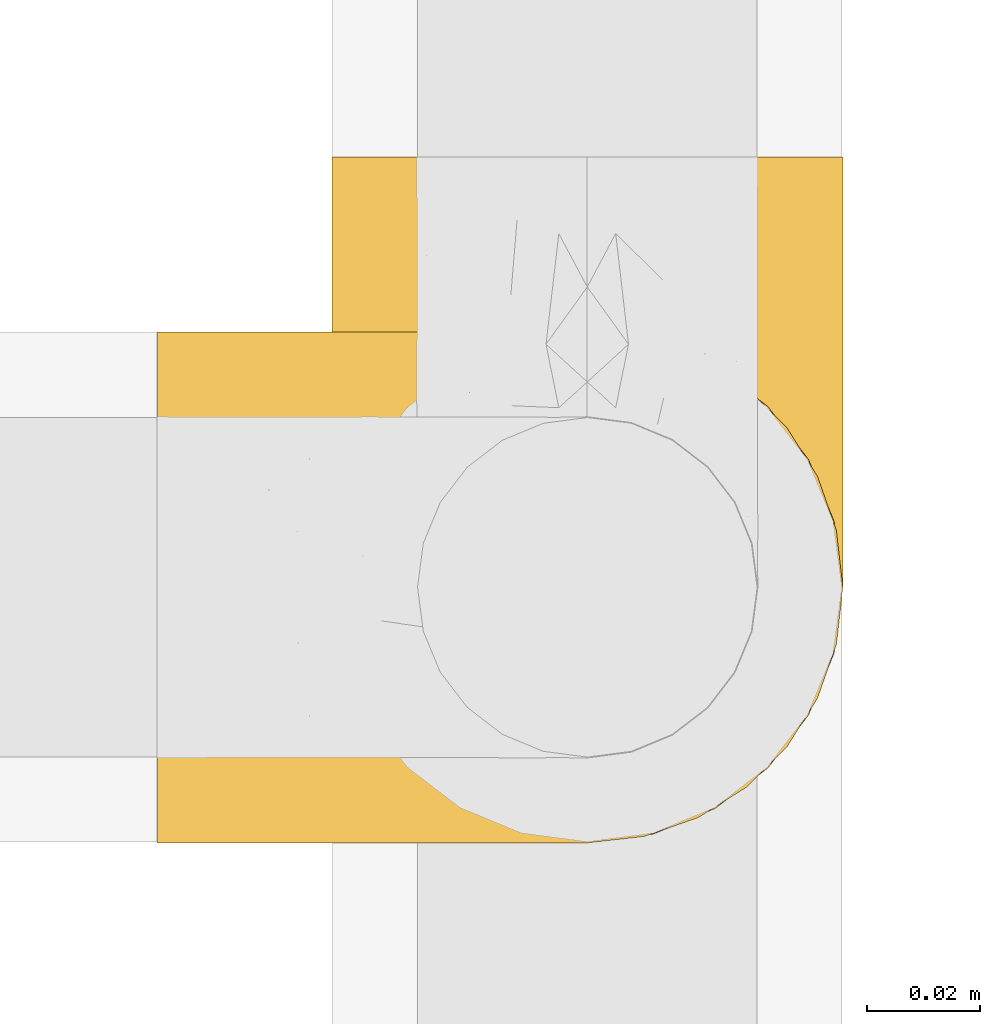
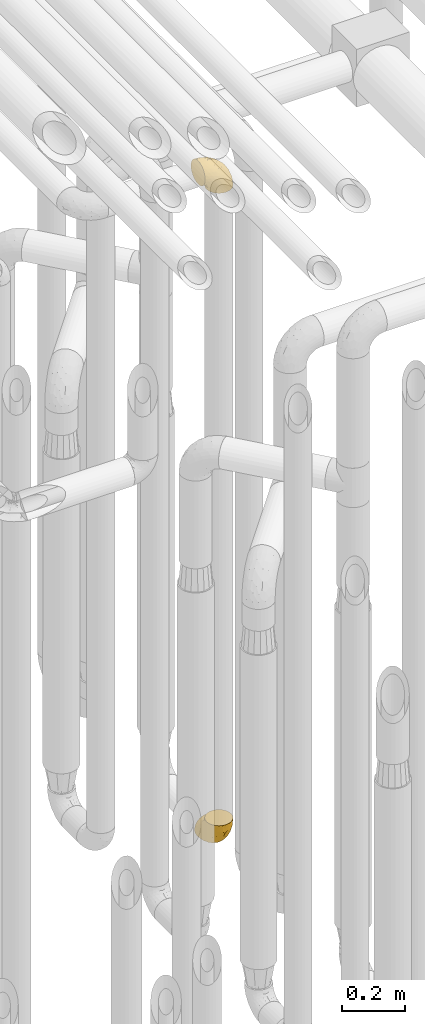
# One storey, part 216 of 827: 2 coverings.
"""IFC2X3 building model written with IfcOpenShell, lengths in millimetres."""

import ifcopenshell
import ifcopenshell.guid

model = None  # the IFC model being written
_history = None  # IfcOwnerHistory: only IFC2X3 demands one
_inside = {}  # id of a spatial element -> (the spatial element, [elements in it])
_under = {}  # id of a project, library or spatial element -> (it, [spatial elements below it])
_declared = {}  # id of a project -> (the project, [libraries it declares])
_typed = {}  # id of a type object -> (the type object, [elements of that type])
_made_of = {}  # id of a material, layer set ... -> (it, [elements and type objects made of it])


def new_model(schema):
    """Start an empty IFC model of exactly this schema.

    Asked for "IFC4X3", IfcOpenShell would pick the latest addendum, in which some entities
    have other attributes; the version numbers below select the first issue.
    IFC2X3 requires an IfcOwnerHistory on every rooted entity: one is made here for all.
    """
    global model, _history
    if schema == "IFC4X3":
        model = ifcopenshell.file(schema_version=(4, 3, 0, 0))
    else:
        model = ifcopenshell.file(schema=schema)
    _inside.clear()
    _under.clear()
    _declared.clear()
    _typed.clear()
    _made_of.clear()
    _history = None
    if model.schema == "IFC2X3":
        org = make("IfcOrganization", Name="unknown")
        user = make(
            "IfcPersonAndOrganization",
            ThePerson=make("IfcPerson", FamilyName="unknown"),
            TheOrganization=org,
        )
        app = make(
            "IfcApplication",
            ApplicationDeveloper=org,
            Version="unknown",
            ApplicationFullName="unknown",
            ApplicationIdentifier="unknown",
        )
        _history = make(
            "IfcOwnerHistory",
            OwningUser=user,
            OwningApplication=app,
            ChangeAction="ADDED",
            CreationDate=0,
        )
    return model


def make(cls, **values):
    """One entity of the class cls with the attributes given. An attribute that is None is left unset."""
    return model.create_entity(
        cls, **{name: value for name, value in values.items() if value is not None}
    )


def entity(cls, *values):
    """Any entity or typed value of the class cls, its attributes in the order of the schema. None: left unset."""
    e = model.create_entity(cls)
    for i, value in enumerate(values):
        if value is not None:
            e[i] = value
    return e


def rooted(cls, **values):
    """An entity with a GlobalId (a new one), such as an element, a storey or a relation."""
    return make(cls, GlobalId=ifcopenshell.guid.new(), OwnerHistory=_history, **values)


def si_unit(unit_type, name, prefix=None):
    """IfcSIUnit, for example si_unit("LENGTHUNIT", "METRE", prefix="MILLI")."""
    return make("IfcSIUnit", UnitType=unit_type, Prefix=prefix, Name=name)


def converted_unit(unit_type, name, factor, base, dimensions=None, offset=None):
    """IfcConversionBasedUnit, such as the inch: factor (a typed value) times the base unit."""
    return make(
        "IfcConversionBasedUnit"
        if offset is None
        else "IfcConversionBasedUnitWithOffset",
        ConversionOffset=offset,
        Dimensions=None
        if dimensions is None
        else entity("IfcDimensionalExponents", *dimensions),
        UnitType=unit_type,
        Name=name,
        ConversionFactor=make(
            "IfcMeasureWithUnit", ValueComponent=factor, UnitComponent=base
        ),
    )


def derived_unit(unit_type, elements):
    """IfcDerivedUnit: a product of units, each with its exponent."""
    return make(
        "IfcDerivedUnit",
        Elements=[
            make("IfcDerivedUnitElement", Unit=unit, Exponent=power)
            for unit, power in elements
        ],
        UnitType=unit_type,
    )


def assignment(units):
    """IfcUnitAssignment: the units of a project."""
    return None if units is None else make("IfcUnitAssignment", Units=units)


def point(xyz):
    """IfcCartesianPoint."""
    return None if xyz is None else make("IfcCartesianPoint", Coordinates=xyz)


def direction(xyz):
    """IfcDirection."""
    return None if xyz is None else make("IfcDirection", DirectionRatios=xyz)


def frame(location, z_axis=None, x_axis=None):
    """IfcAxis2Placement3D, a coordinate frame: its origin and axes. An axis left out is left unset."""
    return make(
        "IfcAxis2Placement3D",
        Location=point(location),
        Axis=direction(z_axis),
        RefDirection=direction(x_axis),
    )


def origin():
    """The frame at (0, 0, 0) with its axes left unset."""
    return frame((0.0, 0.0, 0.0))


def place(relative_to, where):
    """IfcLocalPlacement: puts the frame where relative to a parent placement (None: the world)."""
    return make(
        "IfcLocalPlacement", PlacementRelTo=relative_to, RelativePlacement=where
    )


def context(
    kind, dimensions, precision=None, world=None, true_north=None, identifier=None
):
    """IfcGeometricRepresentationContext, for example the 3D "Model" context."""
    return make(
        "IfcGeometricRepresentationContext",
        ContextIdentifier=identifier,
        ContextType=kind,
        CoordinateSpaceDimension=dimensions,
        Precision=precision,
        WorldCoordinateSystem=world,
        TrueNorth=true_north,
    )


def subcontext(parent, identifier, kind, view, scale=None):
    """IfcGeometricRepresentationSubContext, for example "Body" below "Model"."""
    return make(
        "IfcGeometricRepresentationSubContext",
        ContextIdentifier=identifier,
        ContextType=kind,
        ParentContext=parent,
        TargetScale=scale,
        TargetView=view,
    )


def project(units=None, contexts=None):
    """IfcProject with its units and contexts."""
    return rooted(
        "IfcProject",
        Name="project",
        RepresentationContexts=contexts,
        UnitsInContext=assignment(units),
    )


def spatial(cls, under=None, at=None, **own):
    """A site, building, storey or space (cls), placed at a placement, below another one or the project."""
    s = rooted(cls, ObjectPlacement=at, **own)
    if under is not None:
        _under.setdefault(under.id(), (under, []))[1].append(s)
    return s


def faces_of(points, faces, orient=None, outer=None):
    """IfcFace entities. A face is a list of loops; a loop is a list of indices into points, from 0.

    orient and outer hold one flag for each loop. By default every Orientation is true, the
    first loop of a face is its IfcFaceOuterBound and the others are IfcFaceBound.
    """
    made = []
    for i, loops in enumerate(faces):
        bounds = []
        for j, loop in enumerate(loops):
            is_outer = j == 0 if outer is None else outer[i][j]
            bounds.append(
                make(
                    "IfcFaceOuterBound" if is_outer else "IfcFaceBound",
                    Bound=make("IfcPolyLoop", Polygon=[points[k] for k in loop]),
                    Orientation=True if orient is None else orient[i][j],
                )
            )
        made.append(make("IfcFace", Bounds=bounds))
    return made


def faceted_brep(points, faces, orient=None, outer=None, voids=None):
    """IfcFacetedBrep: a solid bounded by flat faces; with voids (closed shells), ...WithVoids."""
    shared = [point(p) for p in points]
    hull = make("IfcClosedShell", CfsFaces=faces_of(shared, faces, orient, outer))
    if voids is None:
        return make("IfcFacetedBrep", Outer=hull)
    return make(
        "IfcFacetedBrepWithVoids",
        Outer=hull,
        Voids=[
            make(cls, CfsFaces=faces_of(shared, fs, o, b)) for cls, fs, o, b in voids
        ],
    )


def shape(context_of_items, identifier, shape_type, items):
    """IfcShapeRepresentation: the items that make up one representation, for example the "Body"."""
    return make(
        "IfcShapeRepresentation",
        ContextOfItems=context_of_items,
        RepresentationIdentifier=identifier,
        RepresentationType=shape_type,
        Items=items,
    )


def made_of(thing, what):
    """Note that an element or type object is made of a material, layer set ...; save() writes the relation."""
    if what is not None:
        _made_of.setdefault(what.id(), (what, []))[1].append(thing)
    return thing


def element(
    cls,
    number,
    at=None,
    inside=None,
    cuts=None,
    type_object=None,
    material=None,
    context=None,
    identifier="Body",
    shape_type=None,
    held_by="IfcProductDefinitionShape",
    body=None,
    shapes=None,
    **own,
):
    """One element of the class cls, such as IfcWall. Its Tag is "e" and its number.

    at: its placement. inside: the storey or other place that contains it. cuts: it is an
    opening in that element (IfcRelVoidsElement). A single representation is given by context,
    identifier, shape_type and body (its items); several are given by shapes. held_by: the class
    of the entity that holds the representations. save() writes the other relations.
    """
    e = rooted(cls, Tag="e%d" % number, ObjectPlacement=at, **own)
    if body is not None:
        shapes = [shape(context, identifier, shape_type, body)]
    if shapes is not None:
        e.Representation = make(held_by, Representations=shapes)
    if inside is not None:
        _inside.setdefault(inside.id(), (inside, []))[1].append(e)
    if cuts is not None:
        rooted(
            "IfcRelVoidsElement", RelatingBuildingElement=cuts, RelatedOpeningElement=e
        )
    if type_object is not None:
        _typed.setdefault(type_object.id(), (type_object, []))[1].append(e)
    return made_of(e, material)


def aggregate(whole, parts):
    """IfcRelAggregates: a whole, such as a stair, and the parts it consists of."""
    return rooted("IfcRelAggregates", RelatingObject=whole, RelatedObjects=parts)


def save(model, path):
    """Write the relations noted so far, then the file.

    IfcRelAggregates (storeys below a building ...), IfcRelContainedInSpatialStructure (elements
    in a storey), IfcRelDefinesByType, IfcRelAssociatesMaterial and IfcRelDeclares: one each for
    every whole, place, type object, material and project.
    """
    for whole, parts in _under.values():
        aggregate(whole, parts)
    for where, things in _inside.values():
        rooted(
            "IfcRelContainedInSpatialStructure",
            RelatedElements=things,
            RelatingStructure=where,
        )
    for kind, things in _typed.values():
        rooted("IfcRelDefinesByType", RelatedObjects=things, RelatingType=kind)
    for what, things in _made_of.values():
        rooted("IfcRelAssociatesMaterial", RelatedObjects=things, RelatingMaterial=what)
    for by, libraries in _declared.values():
        rooted("IfcRelDeclares", RelatingContext=by, RelatedDefinitions=libraries)
    model.write(path)


model = new_model("IFC2X3")

# Units and contexts
model_context = context("Model", 3, precision=0.01, world=origin(), true_north=direction((6.12303176911189e-17, 1.0)))
body_context = subcontext(model_context, "Body", "Model", "MODEL_VIEW")
ifc_project = project(units=[si_unit("LENGTHUNIT", "METRE", prefix="MILLI"), si_unit("AREAUNIT", "SQUARE_METRE"), si_unit("VOLUMEUNIT", "CUBIC_METRE"), converted_unit("PLANEANGLEUNIT", "DEGREE", entity("IfcRatioMeasure", 0.0174532925199433), si_unit("PLANEANGLEUNIT", "RADIAN"), dimensions=[0, 0, 0, 0, 0, 0, 0]), si_unit("MASSUNIT", "GRAM", prefix="KILO"), derived_unit("MASSDENSITYUNIT", [(si_unit("MASSUNIT", "GRAM", prefix="KILO"), 1), (si_unit("LENGTHUNIT", "METRE"), -3)]), derived_unit("MOMENTOFINERTIAUNIT", [(si_unit("LENGTHUNIT", "METRE"), 4)]), si_unit("TIMEUNIT", "SECOND"), si_unit("FREQUENCYUNIT", "HERTZ"), si_unit("THERMODYNAMICTEMPERATUREUNIT", "DEGREE_CELSIUS"), derived_unit("THERMALTRANSMITTANCEUNIT", [(si_unit("MASSUNIT", "GRAM", prefix="KILO"), 1), (si_unit("THERMODYNAMICTEMPERATUREUNIT", "KELVIN"), -1), (si_unit("TIMEUNIT", "SECOND"), -3)]), derived_unit("VOLUMETRICFLOWRATEUNIT", [(si_unit("LENGTHUNIT", "METRE"), 3), (si_unit("TIMEUNIT", "SECOND"), -1)]), derived_unit("MASSFLOWRATEUNIT", [(si_unit("MASSUNIT", "GRAM", prefix="KILO"), 1), (si_unit("TIMEUNIT", "SECOND"), -1)]), derived_unit("ROTATIONALFREQUENCYUNIT", [(si_unit("TIMEUNIT", "SECOND"), -1)]), si_unit("ELECTRICCURRENTUNIT", "AMPERE"), si_unit("ELECTRICVOLTAGEUNIT", "VOLT"), si_unit("POWERUNIT", "WATT"), si_unit("FORCEUNIT", "NEWTON", prefix="KILO"), si_unit("ILLUMINANCEUNIT", "LUX"), si_unit("LUMINOUSFLUXUNIT", "LUMEN"), si_unit("LUMINOUSINTENSITYUNIT", "CANDELA"), derived_unit("USERDEFINED", [(si_unit("MASSUNIT", "GRAM", prefix="KILO"), -1), (si_unit("LENGTHUNIT", "METRE"), -2), (si_unit("TIMEUNIT", "SECOND"), 3), (si_unit("LUMINOUSFLUXUNIT", "LUMEN"), 1)]), derived_unit("LINEARVELOCITYUNIT", [(si_unit("LENGTHUNIT", "METRE"), 1), (si_unit("TIMEUNIT", "SECOND"), -1)]), si_unit("PRESSUREUNIT", "PASCAL"), derived_unit("USERDEFINED", [(si_unit("LENGTHUNIT", "METRE"), -2), (si_unit("MASSUNIT", "GRAM", prefix="KILO"), 1), (si_unit("TIMEUNIT", "SECOND"), -2)]), derived_unit("LINEARFORCEUNIT", [(si_unit("MASSUNIT", "GRAM", prefix="KILO"), 1), (si_unit("LENGTHUNIT", "METRE"), 1), (si_unit("TIMEUNIT", "SECOND"), -2), (si_unit("LENGTHUNIT", "METRE"), -1)]), derived_unit("PLANARFORCEUNIT", [(si_unit("MASSUNIT", "GRAM", prefix="KILO"), 1), (si_unit("LENGTHUNIT", "METRE"), 1), (si_unit("TIMEUNIT", "SECOND"), -2), (si_unit("LENGTHUNIT", "METRE"), -2)])], contexts=[model_context])

# Site, building, storey
site_placement = place(None, origin())
site = spatial("IfcSite", under=ifc_project, at=site_placement, CompositionType="ELEMENT")
building_placement = place(site_placement, origin())
building = spatial("IfcBuilding", under=site, at=building_placement, CompositionType="ELEMENT")
storey_placement = place(building_placement, frame((0.0, 0.0, 28200.0)))
storey = spatial("IfcBuildingStorey", under=building, at=storey_placement, Name="08", CompositionType="ELEMENT", Elevation=28200.0)

# Coverings
covering_1_placement = place(storey_placement, frame((36897.44, 12134.43, 2922.4)))
element("IfcCovering", 1, at=covering_1_placement, inside=storey, Name=":ADSK_", ObjectType=":ADSK_", PredefinedType="INSULATION", context=body_context, shape_type="Brep", body=[
    faceted_brep([(87.65, 90.76, 1.6), (97.19, 87.42, 1.6), (105.75, 82.04, 1.6), (112.9, 74.89, 1.6), (118.28, 66.33, 1.6), (121.61, 56.79, 1.6), (122.75, 46.75, 1.6), (121.61, 36.69, 1.6), (118.27, 27.15, 1.6), (112.89, 18.59, 1.6), (105.74, 11.44, 1.6), (97.18, 6.06, 1.6), (87.64, 2.73, 1.6), (77.6, 1.6, 1.6), (67.54, 2.73, 1.6), (58.0, 6.07, 1.6), (49.44, 11.45, 1.6), (42.29, 18.6, 1.6), (36.91, 27.16, 1.6), (33.58, 36.7, 1.6), (32.45, 46.75, 1.6), (33.58, 56.8, 1.6), (36.92, 66.34, 1.6), (42.3, 74.9, 1.6), (49.45, 82.05, 1.6), (58.01, 87.43, 1.6), (67.55, 90.76, 1.6), (77.6, 91.9, 1.6), (1.6, 35.06, 33.98), (1.6, 24.17, 38.49), (1.6, 14.82, 45.67), (1.6, 7.64, 55.02), (1.6, 3.13, 65.91), (1.6, 1.6, 77.6), (1.6, 3.13, 89.28), (1.6, 7.64, 100.17), (1.6, 14.82, 109.52), (1.6, 24.17, 116.7), (1.6, 35.06, 121.21), (1.6, 46.75, 122.75), (1.6, 58.43, 121.21), (1.6, 69.32, 116.7), (1.6, 78.67, 109.52), (1.6, 85.85, 100.17), (1.6, 90.36, 89.28), (1.6, 91.9, 77.6), (1.6, 90.36, 65.91), (1.6, 85.85, 55.02), (1.6, 78.67, 45.67), (1.6, 69.32, 38.49), (1.6, 58.43, 33.98), (1.6, 46.75, 32.45), (99.61, 46.75, 72.81), (95.26, 55.2, 77.17), (86.21, 46.75, 86.21), (39.03, 46.75, 116.82), (30.75, 54.53, 118.49), (23.8, 46.75, 119.23), (60.8, 59.63, 105.14), (85.37, 62.07, 85.37), (73.64, 71.86, 89.33), (31.01, 62.65, 116.14), (49.14, 71.33, 105.06), (23.88, 72.93, 112.15), (82.74, 91.2, 22.95), (43.48, 86.31, 89.91), (29.47, 80.89, 103.39), (56.38, 79.49, 93.6), (72.18, 90.68, 51.41), (72.24, 86.84, 67.71), (87.6, 87.38, 43.53), (107.24, 76.87, 30.91), (101.1, 83.73, 23.58), (95.16, 81.03, 50.07), (71.81, 91.9, 30.68), (63.57, 91.9, 43.01), (55.34, 91.9, 55.34), (23.66, 91.03, 83.48), (20.55, 87.58, 94.96), (107.97, 56.52, 57.29), (116.82, 46.75, 39.03), (117.03, 60.4, 30.66), (30.68, 91.9, 71.81), (21.51, 91.9, 73.63), (12.33, 91.9, 75.46), (106.17, 67.87, 51.57), (52.37, 90.35, 73.13), (114.51, 69.57, 23.16), (119.23, 46.75, 23.8), (78.37, 79.91, 75.6), (75.46, 91.9, 12.33), (73.63, 91.9, 21.51), (101.51, 74.99, 50.46), (72.81, 46.75, 99.61), (43.01, 91.9, 63.57), (92.6, 88.53, 21.26), (91.86, 72.65, 69.54), (55.92, 46.75, 108.21), (99.01, 62.97, 68.42), (108.21, 46.75, 55.92), (32.05, 66.2, 19.36), (30.22, 56.6, 15.76), (23.37, 59.89, 26.13), (28.43, 90.95, 62.78), (16.44, 90.22, 63.65), (37.1, 76.64, 24.34), (28.88, 71.58, 28.46), (33.93, 79.99, 33.53), (50.17, 89.54, 39.46), (40.57, 89.97, 51.05), (47.62, 81.32, 10.94), (39.9, 74.56, 14.55), (47.92, 84.15, 22.21), (34.27, 90.37, 57.05), (24.65, 87.82, 54.0), (62.6, 90.98, 29.19), (66.18, 90.96, 18.85), (11.74, 85.14, 52.84), (13.89, 58.11, 31.47), (17.02, 46.75, 28.31), (15.86, 78.39, 43.0), (57.71, 88.22, 16.9), (9.11, 66.06, 35.98), (18.55, 68.6, 33.91), (34.74, 63.78, 9.97), (54.95, 88.42, 25.93), (57.35, 90.61, 35.61), (22.03, 83.8, 47.45), (24.8, 77.98, 38.26), (69.07, 91.22, 11.7), (42.31, 83.46, 30.13), (29.63, 46.75, 12.12), (28.31, 46.75, 17.02), (30.23, 84.66, 44.39), (40.13, 86.33, 39.83), (22.67, 46.75, 22.67), (12.12, 46.75, 29.63), (15.86, 15.1, 43.0), (22.03, 9.69, 47.45), (24.8, 15.52, 38.26), (30.23, 8.83, 44.38), (13.88, 35.39, 31.47), (47.61, 12.18, 10.93), (73.63, 1.6, 21.51), (66.17, 2.53, 18.84), (69.07, 2.27, 11.7), (30.22, 36.9, 15.76), (32.04, 27.31, 19.36), (23.36, 33.62, 26.14), (54.93, 5.07, 25.94), (47.91, 9.36, 22.21), (57.69, 5.27, 16.9), (9.1, 27.43, 35.98), (21.51, 1.6, 73.63), (12.33, 1.6, 75.46), (42.29, 10.05, 30.12), (37.09, 16.87, 24.33), (11.74, 8.35, 52.84), (16.44, 3.27, 63.65), (30.68, 1.6, 71.81), (28.86, 21.94, 28.45), (34.74, 29.72, 9.97), (63.57, 1.6, 43.01), (55.34, 1.6, 55.34), (50.17, 3.96, 39.46), (75.46, 1.6, 12.33), (39.89, 18.95, 14.54), (28.43, 2.54, 62.78), (34.27, 3.12, 57.05), (43.01, 1.6, 63.57), (62.59, 2.51, 29.2), (40.57, 3.52, 51.05), (40.13, 7.17, 39.81), (71.81, 1.6, 30.68), (33.92, 13.52, 33.52), (57.34, 2.88, 35.61), (24.65, 5.67, 54.0), (18.54, 24.89, 33.91), (29.47, 12.6, 103.39), (43.48, 7.18, 89.91), (56.4, 14.0, 93.6), (49.17, 22.16, 105.05), (73.69, 21.61, 89.27), (52.37, 3.14, 73.13), (72.26, 6.65, 67.67), (91.88, 20.82, 69.49), (85.36, 31.41, 85.36), (20.55, 5.91, 94.96), (23.66, 2.46, 83.48), (60.8, 33.87, 105.14), (31.02, 30.84, 116.13), (30.75, 38.96, 118.49), (23.9, 20.56, 112.15), (72.17, 2.81, 51.41), (87.59, 6.1, 43.51), (82.74, 2.29, 22.95), (117.03, 33.08, 30.66), (107.23, 16.61, 30.91), (107.97, 36.96, 57.3), (101.08, 9.75, 23.58), (106.17, 25.61, 51.56), (99.01, 30.5, 68.41), (114.5, 23.91, 23.16), (95.15, 12.45, 50.07), (101.5, 18.49, 50.45), (92.59, 4.96, 21.25), (78.38, 13.56, 75.56), (95.27, 38.28, 77.16)], [[[0, 1, 2, 3, 4, 5, 6, 7, 8, 9, 10, 11, 12, 13, 14, 15, 16, 17, 18, 19, 20, 21, 22, 23, 24, 25, 26, 27]], [[28, 29, 30, 31, 32, 33, 34, 35, 36, 37, 38, 39, 40, 41, 42, 43, 44, 45, 46, 47, 48, 49, 50, 51]], [[52, 53, 54]], [[55, 56, 57]], [[58, 59, 60]], [[61, 62, 63]], [[27, 64, 0]], [[65, 66, 67]], [[41, 40, 61]], [[68, 69, 70]], [[66, 43, 42]], [[63, 42, 41]], [[71, 72, 73]], [[72, 2, 1]], [[68, 74, 75, 76]], [[45, 44, 77]], [[43, 78, 44]], [[79, 80, 81]], [[77, 82, 83, 84, 45]], [[79, 81, 85]], [[71, 2, 72]], [[65, 86, 77]], [[4, 81, 5]], [[66, 65, 78]], [[4, 3, 87]], [[81, 88, 5]], [[63, 66, 42]], [[68, 70, 64]], [[67, 60, 89]], [[71, 3, 2]], [[64, 27, 90, 91, 74]], [[92, 71, 73]], [[40, 57, 56]], [[59, 93, 54]], [[86, 76, 94, 82]], [[1, 0, 95]], [[58, 62, 61]], [[60, 96, 89]], [[85, 81, 87]], [[56, 97, 58]], [[65, 67, 69]], [[87, 81, 4]], [[67, 89, 69]], [[61, 63, 41]], [[95, 72, 1]], [[73, 72, 70]], [[69, 73, 70]], [[73, 89, 96]], [[3, 71, 87]], [[85, 87, 71]], [[58, 61, 56]], [[59, 58, 93]], [[76, 86, 68]], [[69, 89, 73]], [[68, 86, 69]], [[65, 69, 86]], [[68, 64, 74]], [[95, 64, 70]], [[98, 79, 85]], [[79, 52, 99, 80]], [[66, 62, 67]], [[62, 58, 60]], [[62, 60, 67]], [[59, 98, 96]], [[59, 96, 60]], [[96, 85, 92]], [[88, 81, 80]], [[88, 6, 5]], [[66, 63, 62]], [[64, 95, 0]], [[72, 95, 70]], [[77, 44, 78]], [[86, 82, 77]], [[40, 39, 57]], [[96, 98, 85]], [[40, 56, 61]], [[66, 78, 43]], [[77, 78, 65]], [[79, 98, 53]], [[96, 92, 73]], [[85, 71, 92]], [[97, 56, 55]], [[97, 93, 58]], [[53, 98, 59]], [[54, 53, 59]], [[79, 53, 52]], [[100, 101, 102]], [[46, 45, 84, 83]], [[103, 104, 82]], [[82, 104, 83]], [[105, 106, 107]], [[108, 109, 76]], [[110, 111, 112]], [[103, 113, 114]], [[115, 74, 116]], [[48, 47, 117]], [[118, 102, 119]], [[49, 48, 120]], [[74, 91, 116]], [[116, 121, 115]], [[49, 122, 50]], [[123, 106, 102]], [[124, 111, 22]], [[125, 126, 115]], [[23, 22, 111]], [[24, 110, 121]], [[120, 127, 128]], [[90, 26, 129]], [[27, 26, 90]], [[121, 125, 115]], [[24, 121, 25]], [[130, 105, 107]], [[129, 25, 116]], [[21, 20, 131]], [[120, 123, 122]], [[112, 105, 130]], [[50, 118, 51]], [[21, 124, 22]], [[101, 131, 132]], [[117, 120, 48]], [[24, 23, 110]], [[127, 114, 133]], [[75, 108, 76]], [[107, 134, 130]], [[133, 114, 113]], [[129, 116, 91]], [[25, 121, 116]], [[121, 112, 125]], [[75, 74, 115]], [[101, 135, 102]], [[131, 101, 21]], [[101, 100, 124]], [[128, 127, 133]], [[119, 136, 51, 118]], [[104, 47, 46]], [[83, 104, 46]], [[117, 104, 114]], [[101, 124, 21]], [[111, 124, 100]], [[102, 118, 123]], [[133, 134, 107]], [[111, 110, 23]], [[114, 104, 103]], [[94, 76, 109]], [[121, 110, 112]], [[122, 118, 50]], [[134, 109, 108]], [[133, 107, 128]], [[112, 108, 125]], [[126, 125, 108]], [[108, 75, 126]], [[75, 115, 126]], [[109, 134, 133]], [[130, 108, 112]], [[108, 130, 134]], [[105, 112, 111]], [[111, 100, 105]], [[106, 105, 100]], [[102, 106, 100]], [[128, 106, 123]], [[90, 129, 91]], [[25, 129, 26]], [[104, 117, 47]], [[117, 114, 127]], [[82, 94, 103]], [[113, 94, 109]], [[94, 113, 103]], [[133, 113, 109]], [[106, 128, 107]], [[123, 120, 128]], [[120, 122, 49]], [[118, 122, 123]], [[135, 101, 132]], [[135, 119, 102]], [[117, 127, 120]], [[30, 29, 137]], [[138, 139, 140]], [[51, 136, 119, 141]], [[142, 17, 16]], [[143, 144, 145]], [[146, 147, 148]], [[149, 150, 151]], [[152, 29, 28]], [[33, 32, 153, 154]], [[150, 155, 156]], [[157, 31, 30]], [[153, 158, 159]], [[29, 152, 137]], [[148, 141, 119]], [[156, 160, 147]], [[148, 135, 146]], [[137, 138, 157]], [[19, 161, 146]], [[162, 163, 164]], [[14, 13, 165]], [[153, 32, 158]], [[147, 161, 166]], [[18, 17, 166]], [[167, 168, 169]], [[166, 150, 156]], [[151, 150, 142]], [[151, 170, 149]], [[151, 16, 15]], [[171, 140, 172]], [[165, 143, 145]], [[173, 170, 144]], [[142, 166, 17]], [[19, 131, 20]], [[144, 170, 151]], [[18, 161, 19]], [[173, 144, 143]], [[140, 139, 174]], [[171, 164, 163]], [[164, 172, 155]], [[151, 15, 144]], [[145, 15, 14]], [[173, 162, 170]], [[149, 175, 164]], [[19, 146, 131]], [[132, 131, 146]], [[160, 148, 147]], [[159, 158, 167]], [[135, 132, 146]], [[158, 32, 31]], [[157, 158, 31]], [[167, 158, 176]], [[166, 161, 18]], [[146, 161, 147]], [[148, 177, 141]], [[171, 168, 140]], [[171, 163, 169]], [[151, 142, 16]], [[166, 142, 150]], [[152, 141, 177]], [[51, 141, 28]], [[138, 140, 176]], [[172, 140, 174]], [[175, 149, 170]], [[164, 150, 149]], [[170, 162, 175]], [[162, 164, 175]], [[155, 172, 174]], [[171, 172, 164]], [[155, 174, 156]], [[164, 155, 150]], [[160, 156, 174]], [[147, 166, 156]], [[139, 160, 174]], [[148, 160, 177]], [[15, 145, 144]], [[165, 145, 14]], [[137, 157, 30]], [[158, 157, 176]], [[168, 167, 176]], [[169, 159, 167]], [[140, 168, 176]], [[169, 168, 171]], [[137, 177, 139]], [[160, 139, 177]], [[141, 152, 28]], [[137, 152, 177]], [[148, 119, 135]], [[157, 138, 176]], [[139, 138, 137]], [[178, 179, 180]], [[181, 180, 182]], [[179, 183, 184]], [[185, 186, 182]], [[187, 188, 179]], [[188, 33, 154, 153, 159]], [[181, 189, 190]], [[35, 34, 187]], [[191, 38, 190]], [[192, 178, 181]], [[179, 184, 180]], [[192, 190, 37]], [[37, 190, 38]], [[36, 35, 178]], [[54, 93, 186]], [[35, 187, 178]], [[193, 194, 184]], [[195, 173, 143, 165, 13]], [[195, 193, 173]], [[193, 163, 162, 173]], [[13, 12, 195]], [[8, 7, 196]], [[9, 197, 10]], [[198, 80, 99, 52]], [[196, 7, 88]], [[197, 199, 10]], [[182, 189, 181]], [[200, 198, 201]], [[200, 196, 198]], [[9, 8, 202]], [[194, 199, 203]], [[192, 37, 36]], [[80, 196, 88]], [[183, 159, 169, 163]], [[188, 34, 33]], [[202, 200, 197]], [[185, 203, 204]], [[202, 8, 196]], [[10, 199, 11]], [[12, 11, 205]], [[38, 191, 57]], [[189, 97, 191]], [[203, 199, 197]], [[205, 199, 194]], [[204, 203, 197]], [[184, 203, 206]], [[200, 202, 196]], [[197, 9, 202]], [[207, 54, 186]], [[97, 55, 191]], [[194, 203, 184]], [[183, 163, 193]], [[184, 206, 180]], [[183, 193, 184]], [[205, 195, 12]], [[193, 195, 194]], [[80, 198, 196]], [[207, 186, 201]], [[182, 180, 206]], [[181, 178, 180]], [[185, 182, 206]], [[182, 186, 189]], [[203, 185, 206]], [[185, 200, 201]], [[7, 6, 88]], [[178, 192, 36]], [[190, 192, 181]], [[199, 205, 11]], [[195, 205, 194]], [[159, 183, 188]], [[179, 188, 183]], [[57, 191, 55]], [[57, 39, 38]], [[189, 191, 190]], [[188, 187, 34]], [[178, 187, 179]], [[186, 93, 189]], [[197, 200, 204]], [[185, 204, 200]], [[189, 93, 97]], [[207, 198, 52]], [[185, 201, 186]], [[198, 207, 201]], [[54, 207, 52]]]),
])
covering_2_placement = place(storey_placement, frame((36928.29, 12134.43, 353.25)))
element("IfcCovering", 2, at=covering_2_placement, inside=storey, Name=":ADSK_", ObjectType=":ADSK_", PredefinedType="INSULATION", context=body_context, shape_type="Brep", body=[
    faceted_brep([(90.76, 122.75, 36.69), (87.42, 122.75, 27.15), (82.04, 122.75, 18.59), (74.89, 122.75, 11.44), (66.33, 122.75, 6.06), (56.79, 122.75, 2.73), (46.75, 122.75, 1.6), (36.69, 122.75, 2.73), (27.15, 122.75, 6.07), (18.59, 122.75, 11.45), (11.44, 122.75, 18.6), (6.06, 122.75, 27.16), (2.73, 122.75, 36.7), (1.6, 122.75, 46.75), (2.73, 122.75, 56.8), (6.07, 122.75, 66.34), (11.45, 122.75, 74.9), (18.6, 122.75, 82.05), (27.16, 122.75, 87.43), (36.7, 122.75, 90.76), (46.75, 122.75, 91.9), (56.8, 122.75, 90.76), (66.34, 122.75, 87.42), (74.9, 122.75, 82.04), (82.05, 122.75, 74.89), (87.43, 122.75, 66.33), (90.76, 122.75, 56.79), (91.9, 122.75, 46.75), (35.06, 90.36, 122.75), (24.17, 85.85, 122.75), (14.82, 78.67, 122.75), (7.64, 69.32, 122.75), (3.13, 58.43, 122.75), (1.6, 46.75, 122.75), (3.13, 35.06, 122.75), (7.64, 24.17, 122.75), (14.82, 14.82, 122.75), (24.17, 7.64, 122.75), (35.06, 3.13, 122.75), (46.75, 1.6, 122.75), (58.43, 3.13, 122.75), (69.32, 7.64, 122.75), (78.67, 14.82, 122.75), (85.85, 24.17, 122.75), (90.36, 35.06, 122.75), (91.9, 46.75, 122.75), (90.36, 58.43, 122.75), (85.85, 69.32, 122.75), (78.67, 78.67, 122.75), (69.32, 85.85, 122.75), (58.43, 90.36, 122.75), (46.75, 91.9, 122.75), (46.75, 51.54, 24.73), (55.2, 47.17, 29.08), (46.75, 38.13, 38.13), (46.75, 7.52, 85.31), (54.53, 5.85, 93.59), (46.75, 5.11, 100.54), (59.63, 19.2, 63.54), (62.07, 38.98, 38.98), (71.86, 35.02, 50.71), (62.65, 8.21, 93.33), (71.33, 19.28, 75.2), (72.93, 12.19, 100.46), (91.2, 101.39, 41.6), (86.31, 34.43, 80.86), (80.89, 20.95, 94.87), (79.49, 30.74, 67.96), (90.68, 72.93, 52.16), (86.84, 56.64, 52.1), (87.38, 80.81, 36.74), (76.87, 93.43, 17.11), (83.73, 100.76, 23.24), (81.03, 74.27, 29.18), (91.9, 93.66, 52.53), (91.9, 81.33, 60.77), (91.9, 69.01, 69.01), (91.03, 40.87, 100.68), (87.58, 29.38, 103.79), (56.52, 67.05, 16.37), (46.75, 85.31, 7.52), (60.4, 93.68, 7.31), (91.9, 52.53, 93.66), (91.9, 50.71, 102.83), (91.9, 48.88, 112.01), (67.87, 72.77, 18.17), (90.35, 51.21, 71.97), (69.57, 101.18, 9.83), (46.75, 100.54, 5.11), (79.91, 48.74, 45.97), (91.9, 112.01, 48.88), (91.9, 102.83, 50.71), (74.99, 73.88, 22.83), (46.75, 24.73, 51.54), (91.9, 60.77, 81.33), (88.53, 103.08, 31.74), (72.65, 54.8, 32.48), (46.75, 16.13, 68.42), (62.97, 55.92, 25.33), (46.75, 68.42, 16.13), (66.2, 104.98, 92.29), (56.6, 108.58, 94.12), (59.89, 98.21, 100.97), (90.95, 61.56, 95.91), (90.22, 60.69, 107.9), (76.64, 100.0, 87.24), (71.58, 95.88, 95.46), (79.99, 90.81, 90.41), (89.54, 84.88, 74.17), (89.97, 73.29, 83.77), (81.32, 113.4, 76.72), (74.56, 109.8, 84.44), (84.15, 102.13, 76.42), (90.37, 67.29, 90.07), (87.82, 70.34, 99.69), (90.98, 95.15, 61.74), (90.96, 105.49, 58.16), (85.14, 71.5, 112.6), (58.11, 92.87, 110.45), (46.75, 96.03, 107.32), (78.39, 81.34, 108.48), (88.22, 107.44, 66.63), (66.06, 88.36, 115.23), (68.6, 90.43, 105.79), (63.78, 114.37, 89.6), (88.42, 98.41, 69.39), (90.61, 88.73, 66.99), (83.8, 76.89, 102.31), (77.98, 86.08, 99.54), (91.22, 112.64, 55.27), (83.46, 94.21, 82.03), (46.75, 112.22, 94.71), (46.75, 107.32, 96.03), (84.66, 79.95, 94.11), (86.33, 84.51, 84.21), (46.75, 101.67, 101.67), (46.75, 94.71, 112.22), (15.1, 81.34, 108.48), (9.69, 76.89, 102.31), (15.52, 86.08, 99.54), (8.83, 79.96, 94.11), (35.39, 92.87, 110.46), (12.18, 113.41, 76.74), (1.6, 102.83, 50.71), (2.53, 105.5, 58.17), (2.27, 112.64, 55.27), (36.9, 108.58, 94.12), (27.31, 104.98, 92.3), (33.62, 98.2, 100.98), (5.07, 98.4, 69.41), (9.36, 102.13, 76.44), (5.27, 107.44, 66.65), (27.43, 88.36, 115.24), (1.6, 50.71, 102.83), (1.6, 48.88, 112.01), (10.05, 94.22, 82.05), (16.87, 100.01, 87.25), (8.35, 71.5, 112.6), (3.27, 60.69, 107.9), (1.6, 52.53, 93.66), (21.94, 95.89, 95.48), (29.72, 114.37, 89.6), (1.6, 81.33, 60.77), (1.6, 69.01, 69.01), (3.96, 84.88, 74.17), (1.6, 112.01, 48.88), (18.95, 109.8, 84.45), (2.54, 61.56, 95.91), (3.12, 67.29, 90.07), (1.6, 60.77, 81.33), (2.51, 95.14, 61.75), (3.52, 73.29, 83.77), (7.17, 84.53, 84.21), (1.6, 93.66, 52.53), (13.52, 90.82, 90.42), (2.88, 88.73, 67.0), (5.67, 70.34, 99.69), (24.89, 90.43, 105.8), (12.6, 20.95, 94.87), (7.18, 34.43, 80.86), (14.0, 30.74, 67.95), (22.16, 19.29, 75.17), (21.61, 35.07, 50.65), (3.14, 51.21, 71.97), (6.65, 56.67, 52.08), (20.82, 54.85, 32.46), (31.41, 38.98, 38.98), (5.91, 29.38, 103.79), (2.46, 40.87, 100.68), (33.87, 19.2, 63.54), (30.84, 8.21, 93.32), (38.96, 5.85, 93.59), (20.56, 12.19, 100.44), (2.81, 72.93, 52.17), (6.1, 80.83, 36.75), (2.29, 101.39, 41.61), (33.08, 93.69, 7.31), (16.61, 93.43, 17.12), (36.96, 67.04, 16.37), (9.75, 100.76, 23.26), (25.61, 72.78, 18.17), (30.5, 55.93, 25.33), (23.91, 101.18, 9.84), (12.45, 74.27, 29.19), (18.49, 73.89, 22.84), (4.96, 103.09, 31.75), (13.56, 48.78, 45.96), (38.28, 47.19, 29.07)], [[[0, 1, 2, 3, 4, 5, 6, 7, 8, 9, 10, 11, 12, 13, 14, 15, 16, 17, 18, 19, 20, 21, 22, 23, 24, 25, 26, 27]], [[28, 29, 30, 31, 32, 33, 34, 35, 36, 37, 38, 39, 40, 41, 42, 43, 44, 45, 46, 47, 48, 49, 50, 51]], [[52, 53, 54]], [[55, 56, 57]], [[58, 59, 60]], [[61, 62, 63]], [[27, 64, 0]], [[65, 66, 67]], [[41, 40, 61]], [[68, 69, 70]], [[66, 43, 42]], [[63, 42, 41]], [[71, 72, 73]], [[72, 2, 1]], [[68, 74, 75, 76]], [[45, 44, 77]], [[43, 78, 44]], [[79, 80, 81]], [[77, 82, 83, 84, 45]], [[79, 81, 85]], [[71, 2, 72]], [[65, 86, 77]], [[4, 81, 5]], [[66, 65, 78]], [[4, 3, 87]], [[81, 88, 5]], [[63, 66, 42]], [[68, 70, 64]], [[67, 60, 89]], [[71, 3, 2]], [[64, 27, 90, 91, 74]], [[92, 71, 73]], [[40, 57, 56]], [[59, 93, 54]], [[86, 76, 94, 82]], [[1, 0, 95]], [[58, 62, 61]], [[60, 96, 89]], [[85, 81, 87]], [[56, 97, 58]], [[65, 67, 69]], [[87, 81, 4]], [[67, 89, 69]], [[61, 63, 41]], [[95, 72, 1]], [[73, 72, 70]], [[69, 73, 70]], [[73, 89, 96]], [[3, 71, 87]], [[85, 87, 71]], [[58, 61, 56]], [[59, 58, 93]], [[76, 86, 68]], [[69, 89, 73]], [[68, 86, 69]], [[65, 69, 86]], [[68, 64, 74]], [[95, 64, 70]], [[98, 79, 85]], [[79, 52, 99, 80]], [[66, 62, 67]], [[62, 58, 60]], [[62, 60, 67]], [[59, 98, 96]], [[59, 96, 60]], [[96, 85, 92]], [[88, 81, 80]], [[88, 6, 5]], [[66, 63, 62]], [[64, 95, 0]], [[72, 95, 70]], [[77, 44, 78]], [[86, 82, 77]], [[40, 39, 57]], [[96, 98, 85]], [[40, 56, 61]], [[66, 78, 43]], [[77, 78, 65]], [[79, 98, 53]], [[96, 92, 73]], [[85, 71, 92]], [[97, 56, 55]], [[97, 93, 58]], [[53, 98, 59]], [[54, 53, 59]], [[79, 53, 52]], [[100, 101, 102]], [[46, 45, 84, 83]], [[103, 104, 82]], [[82, 104, 83]], [[105, 106, 107]], [[108, 109, 76]], [[110, 111, 112]], [[103, 113, 114]], [[115, 74, 116]], [[48, 47, 117]], [[118, 102, 119]], [[49, 48, 120]], [[74, 91, 116]], [[116, 121, 115]], [[49, 122, 50]], [[123, 106, 102]], [[124, 111, 22]], [[125, 126, 115]], [[23, 22, 111]], [[24, 110, 121]], [[120, 127, 128]], [[90, 26, 129]], [[27, 26, 90]], [[121, 125, 115]], [[24, 121, 25]], [[130, 105, 107]], [[129, 25, 116]], [[21, 20, 131]], [[120, 123, 122]], [[112, 105, 130]], [[50, 118, 51]], [[21, 124, 22]], [[101, 131, 132]], [[117, 120, 48]], [[24, 23, 110]], [[127, 114, 133]], [[75, 108, 76]], [[107, 134, 130]], [[133, 114, 113]], [[129, 116, 91]], [[25, 121, 116]], [[121, 112, 125]], [[75, 74, 115]], [[101, 135, 102]], [[131, 101, 21]], [[101, 100, 124]], [[128, 127, 133]], [[119, 136, 51, 118]], [[104, 47, 46]], [[83, 104, 46]], [[117, 104, 114]], [[101, 124, 21]], [[111, 124, 100]], [[102, 118, 123]], [[133, 134, 107]], [[111, 110, 23]], [[114, 104, 103]], [[94, 76, 109]], [[121, 110, 112]], [[122, 118, 50]], [[134, 109, 108]], [[133, 107, 128]], [[112, 108, 125]], [[126, 125, 108]], [[108, 75, 126]], [[75, 115, 126]], [[109, 134, 133]], [[130, 108, 112]], [[108, 130, 134]], [[105, 112, 111]], [[111, 100, 105]], [[106, 105, 100]], [[102, 106, 100]], [[128, 106, 123]], [[90, 129, 91]], [[25, 129, 26]], [[104, 117, 47]], [[117, 114, 127]], [[82, 94, 103]], [[113, 94, 109]], [[94, 113, 103]], [[133, 113, 109]], [[106, 128, 107]], [[123, 120, 128]], [[120, 122, 49]], [[118, 122, 123]], [[135, 101, 132]], [[135, 119, 102]], [[117, 127, 120]], [[30, 29, 137]], [[138, 139, 140]], [[51, 136, 119, 141]], [[142, 17, 16]], [[143, 144, 145]], [[146, 147, 148]], [[149, 150, 151]], [[152, 29, 28]], [[33, 32, 153, 154]], [[150, 155, 156]], [[157, 31, 30]], [[153, 158, 159]], [[29, 152, 137]], [[148, 141, 119]], [[156, 160, 147]], [[148, 135, 146]], [[137, 138, 157]], [[19, 161, 146]], [[162, 163, 164]], [[14, 13, 165]], [[153, 32, 158]], [[147, 161, 166]], [[18, 17, 166]], [[167, 168, 169]], [[166, 150, 156]], [[151, 150, 142]], [[151, 170, 149]], [[151, 16, 15]], [[171, 140, 172]], [[165, 143, 145]], [[173, 170, 144]], [[142, 166, 17]], [[19, 131, 20]], [[144, 170, 151]], [[18, 161, 19]], [[173, 144, 143]], [[140, 139, 174]], [[171, 164, 163]], [[164, 172, 155]], [[151, 15, 144]], [[145, 15, 14]], [[173, 162, 170]], [[149, 175, 164]], [[19, 146, 131]], [[132, 131, 146]], [[160, 148, 147]], [[159, 158, 167]], [[135, 132, 146]], [[158, 32, 31]], [[157, 158, 31]], [[167, 158, 176]], [[166, 161, 18]], [[146, 161, 147]], [[148, 177, 141]], [[171, 168, 140]], [[171, 163, 169]], [[151, 142, 16]], [[166, 142, 150]], [[152, 141, 177]], [[51, 141, 28]], [[138, 140, 176]], [[172, 140, 174]], [[175, 149, 170]], [[164, 150, 149]], [[170, 162, 175]], [[162, 164, 175]], [[155, 172, 174]], [[171, 172, 164]], [[155, 174, 156]], [[164, 155, 150]], [[160, 156, 174]], [[147, 166, 156]], [[139, 160, 174]], [[148, 160, 177]], [[15, 145, 144]], [[165, 145, 14]], [[137, 157, 30]], [[158, 157, 176]], [[168, 167, 176]], [[169, 159, 167]], [[140, 168, 176]], [[169, 168, 171]], [[137, 177, 139]], [[160, 139, 177]], [[141, 152, 28]], [[137, 152, 177]], [[148, 119, 135]], [[157, 138, 176]], [[139, 138, 137]], [[178, 179, 180]], [[181, 180, 182]], [[179, 183, 184]], [[185, 186, 182]], [[187, 188, 179]], [[188, 33, 154, 153, 159]], [[181, 189, 190]], [[35, 34, 187]], [[191, 38, 190]], [[192, 178, 181]], [[179, 184, 180]], [[192, 190, 37]], [[37, 190, 38]], [[36, 35, 178]], [[54, 93, 186]], [[35, 187, 178]], [[193, 194, 184]], [[195, 173, 143, 165, 13]], [[195, 193, 173]], [[193, 163, 162, 173]], [[13, 12, 195]], [[8, 7, 196]], [[9, 197, 10]], [[198, 80, 99, 52]], [[196, 7, 88]], [[197, 199, 10]], [[182, 189, 181]], [[200, 198, 201]], [[200, 196, 198]], [[9, 8, 202]], [[194, 199, 203]], [[192, 37, 36]], [[80, 196, 88]], [[183, 159, 169, 163]], [[188, 34, 33]], [[202, 200, 197]], [[185, 203, 204]], [[202, 8, 196]], [[10, 199, 11]], [[12, 11, 205]], [[38, 191, 57]], [[189, 97, 191]], [[203, 199, 197]], [[205, 199, 194]], [[204, 203, 197]], [[184, 203, 206]], [[200, 202, 196]], [[197, 9, 202]], [[207, 54, 186]], [[97, 55, 191]], [[194, 203, 184]], [[183, 163, 193]], [[184, 206, 180]], [[183, 193, 184]], [[205, 195, 12]], [[193, 195, 194]], [[80, 198, 196]], [[207, 186, 201]], [[182, 180, 206]], [[181, 178, 180]], [[185, 182, 206]], [[182, 186, 189]], [[203, 185, 206]], [[185, 200, 201]], [[7, 6, 88]], [[178, 192, 36]], [[190, 192, 181]], [[199, 205, 11]], [[195, 205, 194]], [[159, 183, 188]], [[179, 188, 183]], [[57, 191, 55]], [[57, 39, 38]], [[189, 191, 190]], [[188, 187, 34]], [[178, 187, 179]], [[186, 93, 189]], [[197, 200, 204]], [[185, 204, 200]], [[189, 93, 97]], [[207, 198, 52]], [[185, 201, 186]], [[198, 207, 201]], [[54, 207, 52]]]),
])

save(model, "model.ifc")
